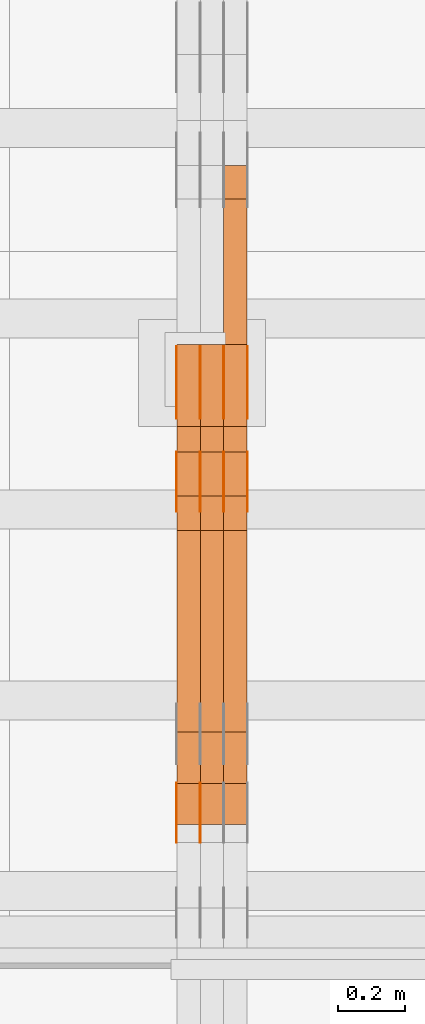
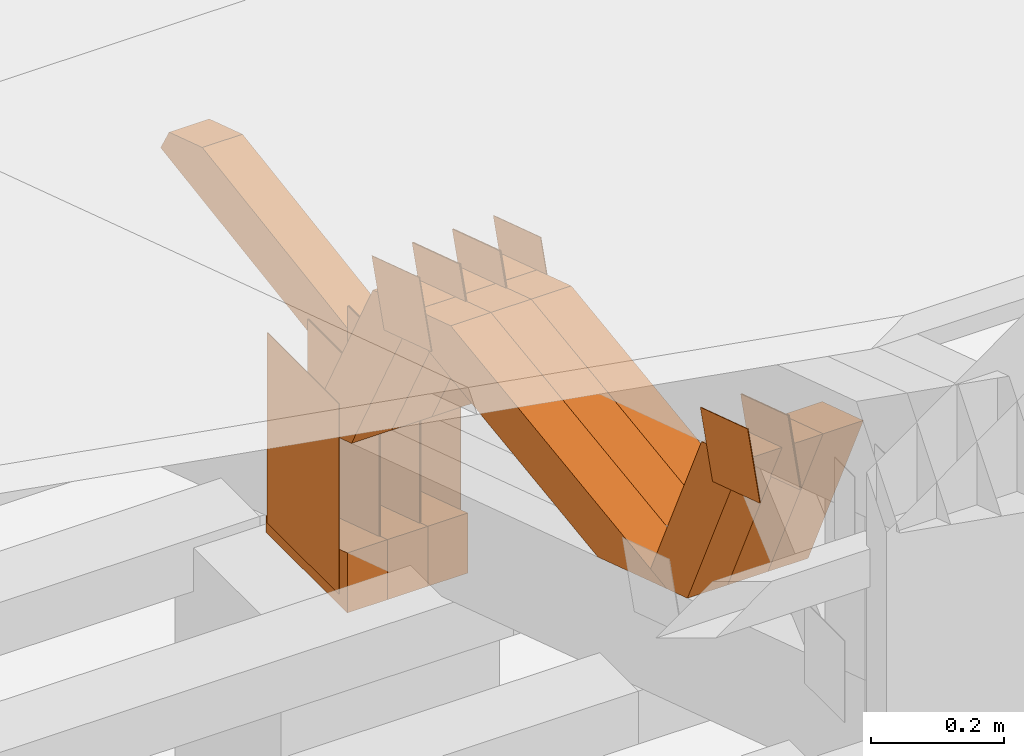
# One storey, part 148 of 385: 28 proxies.
"""IFC2X3 building model written with IfcOpenShell, lengths in millimetres."""

import ifcopenshell
import ifcopenshell.guid

model = None  # the IFC model being written
_history = None  # IfcOwnerHistory: only IFC2X3 demands one
_inside = {}  # id of a spatial element -> (the spatial element, [elements in it])
_under = {}  # id of a project, library or spatial element -> (it, [spatial elements below it])
_declared = {}  # id of a project -> (the project, [libraries it declares])
_typed = {}  # id of a type object -> (the type object, [elements of that type])
_made_of = {}  # id of a material, layer set ... -> (it, [elements and type objects made of it])


def new_model(schema):
    """Start an empty IFC model of exactly this schema.

    Asked for "IFC4X3", IfcOpenShell would pick the latest addendum, in which some entities
    have other attributes; the version numbers below select the first issue.
    IFC2X3 requires an IfcOwnerHistory on every rooted entity: one is made here for all.
    """
    global model, _history
    if schema == "IFC4X3":
        model = ifcopenshell.file(schema_version=(4, 3, 0, 0))
    else:
        model = ifcopenshell.file(schema=schema)
    _inside.clear()
    _under.clear()
    _declared.clear()
    _typed.clear()
    _made_of.clear()
    _history = None
    if model.schema == "IFC2X3":
        org = make("IfcOrganization", Name="unknown")
        user = make(
            "IfcPersonAndOrganization",
            ThePerson=make("IfcPerson", FamilyName="unknown"),
            TheOrganization=org,
        )
        app = make(
            "IfcApplication",
            ApplicationDeveloper=org,
            Version="unknown",
            ApplicationFullName="unknown",
            ApplicationIdentifier="unknown",
        )
        _history = make(
            "IfcOwnerHistory",
            OwningUser=user,
            OwningApplication=app,
            ChangeAction="ADDED",
            CreationDate=0,
        )
    return model


def make(cls, **values):
    """One entity of the class cls with the attributes given. An attribute that is None is left unset."""
    return model.create_entity(
        cls, **{name: value for name, value in values.items() if value is not None}
    )


def entity(cls, *values):
    """Any entity or typed value of the class cls, its attributes in the order of the schema. None: left unset."""
    e = model.create_entity(cls)
    for i, value in enumerate(values):
        if value is not None:
            e[i] = value
    return e


def rooted(cls, **values):
    """An entity with a GlobalId (a new one), such as an element, a storey or a relation."""
    return make(cls, GlobalId=ifcopenshell.guid.new(), OwnerHistory=_history, **values)


def si_unit(unit_type, name, prefix=None):
    """IfcSIUnit, for example si_unit("LENGTHUNIT", "METRE", prefix="MILLI")."""
    return make("IfcSIUnit", UnitType=unit_type, Prefix=prefix, Name=name)


def converted_unit(unit_type, name, factor, base, dimensions=None, offset=None):
    """IfcConversionBasedUnit, such as the inch: factor (a typed value) times the base unit."""
    return make(
        "IfcConversionBasedUnit"
        if offset is None
        else "IfcConversionBasedUnitWithOffset",
        ConversionOffset=offset,
        Dimensions=None
        if dimensions is None
        else entity("IfcDimensionalExponents", *dimensions),
        UnitType=unit_type,
        Name=name,
        ConversionFactor=make(
            "IfcMeasureWithUnit", ValueComponent=factor, UnitComponent=base
        ),
    )


def derived_unit(unit_type, elements):
    """IfcDerivedUnit: a product of units, each with its exponent."""
    return make(
        "IfcDerivedUnit",
        Elements=[
            make("IfcDerivedUnitElement", Unit=unit, Exponent=power)
            for unit, power in elements
        ],
        UnitType=unit_type,
    )


def assignment(units):
    """IfcUnitAssignment: the units of a project."""
    return None if units is None else make("IfcUnitAssignment", Units=units)


def point(xyz):
    """IfcCartesianPoint."""
    return None if xyz is None else make("IfcCartesianPoint", Coordinates=xyz)


def direction(xyz):
    """IfcDirection."""
    return None if xyz is None else make("IfcDirection", DirectionRatios=xyz)


def frame(location, z_axis=None, x_axis=None):
    """IfcAxis2Placement3D, a coordinate frame: its origin and axes. An axis left out is left unset."""
    return make(
        "IfcAxis2Placement3D",
        Location=point(location),
        Axis=direction(z_axis),
        RefDirection=direction(x_axis),
    )


def frame_2d(location, x_axis=None):
    """IfcAxis2Placement2D, a coordinate frame in the plane: its origin and x axis."""
    return make(
        "IfcAxis2Placement2D", Location=point(location), RefDirection=direction(x_axis)
    )


def origin():
    """The frame at (0, 0, 0) with its axes left unset."""
    return frame((0.0, 0.0, 0.0))


def origin_2d_with_axis():
    """The frame at (0, 0) in the plane with the x axis (1, 0) written out."""
    return frame_2d((0.0, 0.0), x_axis=(1.0, 0.0))


def place(relative_to, where):
    """IfcLocalPlacement: puts the frame where relative to a parent placement (None: the world)."""
    return make(
        "IfcLocalPlacement", PlacementRelTo=relative_to, RelativePlacement=where
    )


def context(
    kind, dimensions, precision=None, world=None, true_north=None, identifier=None
):
    """IfcGeometricRepresentationContext, for example the 3D "Model" context."""
    return make(
        "IfcGeometricRepresentationContext",
        ContextIdentifier=identifier,
        ContextType=kind,
        CoordinateSpaceDimension=dimensions,
        Precision=precision,
        WorldCoordinateSystem=world,
        TrueNorth=true_north,
    )


def subcontext(parent, identifier, kind, view, scale=None):
    """IfcGeometricRepresentationSubContext, for example "Body" below "Model"."""
    return make(
        "IfcGeometricRepresentationSubContext",
        ContextIdentifier=identifier,
        ContextType=kind,
        ParentContext=parent,
        TargetScale=scale,
        TargetView=view,
    )


def project(units=None, contexts=None):
    """IfcProject with its units and contexts."""
    return rooted(
        "IfcProject",
        Name="project",
        RepresentationContexts=contexts,
        UnitsInContext=assignment(units),
    )


def spatial(cls, under=None, at=None, **own):
    """A site, building, storey or space (cls), placed at a placement, below another one or the project."""
    s = rooted(cls, ObjectPlacement=at, **own)
    if under is not None:
        _under.setdefault(under.id(), (under, []))[1].append(s)
    return s


def polyline(points):
    """IfcPolyline through the points."""
    return make("IfcPolyline", Points=[point(p) for p in points])


def profile(cls, at=None, kind="AREA", **sizes):
    """A parametric profile (cls). Its sizes go by their IFC names, for example OverallWidth=200.0."""
    return make(cls, ProfileType=kind, Position=at, **sizes)


def rectangle(**sizes):
    """IfcRectangleProfileDef."""
    return profile("IfcRectangleProfileDef", **sizes)


def outline(outer, holes=None, kind="AREA"):
    """IfcArbitraryClosedProfileDef: a profile drawn as a closed curve; with holes, ...WithVoids."""
    if holes is None:
        return make("IfcArbitraryClosedProfileDef", ProfileType=kind, OuterCurve=outer)
    return make(
        "IfcArbitraryProfileDefWithVoids",
        ProfileType=kind,
        OuterCurve=outer,
        InnerCurves=holes,
    )


def extrude(swept, where, along, depth):
    """IfcExtrudedAreaSolid: the profile swept, set in the frame where, extruded along a direction by depth."""
    return make(
        "IfcExtrudedAreaSolid",
        SweptArea=swept,
        Position=where,
        ExtrudedDirection=direction(along),
        Depth=depth,
    )


def shape(context_of_items, identifier, shape_type, items):
    """IfcShapeRepresentation: the items that make up one representation, for example the "Body"."""
    return make(
        "IfcShapeRepresentation",
        ContextOfItems=context_of_items,
        RepresentationIdentifier=identifier,
        RepresentationType=shape_type,
        Items=items,
    )


def source(mapping_origin, context_of_items, identifier, shape_type, items):
    """IfcRepresentationMap: a shape defined once, which mapped items show again and again."""
    return make(
        "IfcRepresentationMap",
        MappingOrigin=mapping_origin,
        MappedRepresentation=shape(context_of_items, identifier, shape_type, items),
    )


def transform(
    local_origin,
    x_axis=None,
    y_axis=None,
    z_axis=None,
    scale=None,
    scale2=None,
    scale3=None,
    uniform=True,
):
    """IfcCartesianTransformationOperator3D, or its non-uniform kind. x_axis, y_axis, z_axis: its Axis1, 2, 3."""
    if uniform:
        return make(
            "IfcCartesianTransformationOperator3D",
            Axis1=direction(x_axis),
            Axis2=direction(y_axis),
            LocalOrigin=point(local_origin),
            Scale=scale,
            Axis3=direction(z_axis),
        )
    return make(
        "IfcCartesianTransformationOperator3DnonUniform",
        Axis1=direction(x_axis),
        Axis2=direction(y_axis),
        LocalOrigin=point(local_origin),
        Scale=scale,
        Axis3=direction(z_axis),
        Scale2=scale2,
        Scale3=scale3,
    )


def mapped(mapping_source, mapping_target):
    """IfcMappedItem: shows the shape of a source again, moved by a transform."""
    return make(
        "IfcMappedItem", MappingSource=mapping_source, MappingTarget=mapping_target
    )


def material(Name=None, Category=None):
    """IfcMaterial."""
    return make("IfcMaterial", Name=Name, Category=Category)


def made_of(thing, what):
    """Note that an element or type object is made of a material, layer set ...; save() writes the relation."""
    if what is not None:
        _made_of.setdefault(what.id(), (what, []))[1].append(thing)
    return thing


def type_object(cls, material=None, **own):
    """A type object (cls), such as IfcWallType, which elements share."""
    return made_of(rooted(cls, **own), material)


def type_shapes(of_type, sources):
    """Give a type object the sources (RepresentationMaps) that its elements show as mapped items."""
    of_type.RepresentationMaps = sources


def element(
    cls,
    number,
    at=None,
    inside=None,
    cuts=None,
    type_object=None,
    material=None,
    context=None,
    identifier="Body",
    shape_type=None,
    held_by="IfcProductDefinitionShape",
    body=None,
    shapes=None,
    **own,
):
    """One element of the class cls, such as IfcWall. Its Tag is "e" and its number.

    at: its placement. inside: the storey or other place that contains it. cuts: it is an
    opening in that element (IfcRelVoidsElement). A single representation is given by context,
    identifier, shape_type and body (its items); several are given by shapes. held_by: the class
    of the entity that holds the representations. save() writes the other relations.
    """
    e = rooted(cls, Tag="e%d" % number, ObjectPlacement=at, **own)
    if body is not None:
        shapes = [shape(context, identifier, shape_type, body)]
    if shapes is not None:
        e.Representation = make(held_by, Representations=shapes)
    if inside is not None:
        _inside.setdefault(inside.id(), (inside, []))[1].append(e)
    if cuts is not None:
        rooted(
            "IfcRelVoidsElement", RelatingBuildingElement=cuts, RelatedOpeningElement=e
        )
    if type_object is not None:
        _typed.setdefault(type_object.id(), (type_object, []))[1].append(e)
    return made_of(e, material)


def aggregate(whole, parts):
    """IfcRelAggregates: a whole, such as a stair, and the parts it consists of."""
    return rooted("IfcRelAggregates", RelatingObject=whole, RelatedObjects=parts)


def save(model, path):
    """Write the relations noted so far, then the file.

    IfcRelAggregates (storeys below a building ...), IfcRelContainedInSpatialStructure (elements
    in a storey), IfcRelDefinesByType, IfcRelAssociatesMaterial and IfcRelDeclares: one each for
    every whole, place, type object, material and project.
    """
    for whole, parts in _under.values():
        aggregate(whole, parts)
    for where, things in _inside.values():
        rooted(
            "IfcRelContainedInSpatialStructure",
            RelatedElements=things,
            RelatingStructure=where,
        )
    for kind, things in _typed.values():
        rooted("IfcRelDefinesByType", RelatedObjects=things, RelatingType=kind)
    for what, things in _made_of.values():
        rooted("IfcRelAssociatesMaterial", RelatedObjects=things, RelatingMaterial=what)
    for by, libraries in _declared.values():
        rooted("IfcRelDeclares", RelatingContext=by, RelatedDefinitions=libraries)
    model.write(path)


model = new_model("IFC2X3")

# Units and contexts
model_context = context("Model", 3, precision=0.01, world=origin(), true_north=direction((6.12303176911189e-17, 1.0)))
body_context = subcontext(model_context, "Body", "Model", "MODEL_VIEW")
ifc_project = project(units=[si_unit("LENGTHUNIT", "METRE", prefix="MILLI"), si_unit("AREAUNIT", "SQUARE_METRE"), si_unit("VOLUMEUNIT", "CUBIC_METRE"), converted_unit("PLANEANGLEUNIT", "DEGREE", entity("IfcRatioMeasure", 0.0174532925199433), si_unit("PLANEANGLEUNIT", "RADIAN"), dimensions=[0, 0, 0, 0, 0, 0, 0]), si_unit("MASSUNIT", "GRAM", prefix="KILO"), derived_unit("MASSDENSITYUNIT", [(si_unit("MASSUNIT", "GRAM", prefix="KILO"), 1), (si_unit("LENGTHUNIT", "METRE"), -3)]), si_unit("TIMEUNIT", "SECOND"), si_unit("FREQUENCYUNIT", "HERTZ"), si_unit("THERMODYNAMICTEMPERATUREUNIT", "DEGREE_CELSIUS"), derived_unit("THERMALTRANSMITTANCEUNIT", [(si_unit("MASSUNIT", "GRAM", prefix="KILO"), 1), (si_unit("THERMODYNAMICTEMPERATUREUNIT", "KELVIN"), -1), (si_unit("TIMEUNIT", "SECOND"), -3)]), derived_unit("VOLUMETRICFLOWRATEUNIT", [(si_unit("LENGTHUNIT", "METRE"), 3), (si_unit("TIMEUNIT", "SECOND"), -1)]), si_unit("ELECTRICCURRENTUNIT", "AMPERE"), si_unit("ELECTRICVOLTAGEUNIT", "VOLT"), si_unit("POWERUNIT", "WATT"), si_unit("FORCEUNIT", "NEWTON", prefix="KILO"), si_unit("ILLUMINANCEUNIT", "LUX"), si_unit("LUMINOUSFLUXUNIT", "LUMEN"), si_unit("LUMINOUSINTENSITYUNIT", "CANDELA"), derived_unit("USERDEFINED", [(si_unit("MASSUNIT", "GRAM", prefix="KILO"), -1), (si_unit("LENGTHUNIT", "METRE"), -2), (si_unit("TIMEUNIT", "SECOND"), 3), (si_unit("LUMINOUSFLUXUNIT", "LUMEN"), 1)]), derived_unit("LINEARVELOCITYUNIT", [(si_unit("LENGTHUNIT", "METRE"), 1), (si_unit("TIMEUNIT", "SECOND"), -1)]), si_unit("PRESSUREUNIT", "PASCAL"), derived_unit("USERDEFINED", [(si_unit("LENGTHUNIT", "METRE"), -2), (si_unit("MASSUNIT", "GRAM", prefix="KILO"), 1), (si_unit("TIMEUNIT", "SECOND"), -2)])], contexts=[model_context])

# Site, building, storey
site_placement = place(None, origin())
site = spatial("IfcSite", under=ifc_project, at=site_placement, CompositionType="ELEMENT")
building_placement = place(site_placement, origin())
building = spatial("IfcBuilding", under=site, at=building_placement, CompositionType="ELEMENT")
storey_placement = place(building_placement, origin())
storey = spatial("IfcBuildingStorey", under=building, at=storey_placement, Name="Default", CompositionType="ELEMENT", Elevation=0.0)

# Proxies
ifc_material_1 = material(Name="IfcSurfaceStyle #237074")
building_element_proxy_type_1 = type_object("IfcBuildingElementProxyType", PredefinedType="NOTDEFINED", material=ifc_material_1)
shared_shape_1 = source(origin(), body_context, "Body", "SweptSolid", [
    extrude(rectangle(XDim=350.0, YDim=215.999999999984, at=origin_2d_with_axis()), frame((175.0, 108.0, 0.0), z_axis=(0.0, 0.0, 1.0), x_axis=(-1.0, 0.0, 0.0)), (0.0, 0.0, 1.0), 1.29999999999999),
])
type_shapes(building_element_proxy_type_1, [shared_shape_1])
proxy_1_placement = place(building_placement, frame((18386.3, 17459.2939453125, 3165.36425781251), z_axis=(-1.0, 0.0, 0.0), x_axis=(0.0, 0.0, -1.0)))
element("IfcBuildingElementProxy", 1, at=proxy_1_placement, inside=storey, type_object=building_element_proxy_type_1, material=ifc_material_1, context=body_context, shape_type="MappedRepresentation", body=[
    mapped(shared_shape_1, transform((0.0, 0.0, 0.0), scale=1.0)),
])
ifc_material_2 = material(Name="IfcSurfaceStyle #237017")
building_element_proxy_type_2 = type_object("IfcBuildingElementProxyType", PredefinedType="NOTDEFINED", material=ifc_material_2)
shared_shape_2 = source(origin(), body_context, "Body", "SweptSolid", [
    extrude(rectangle(XDim=350.0, YDim=215.999999999984, at=origin_2d_with_axis()), frame((175.0, 108.0, 0.0), z_axis=(0.0, 0.0, 1.0), x_axis=(-1.0, 0.0, 0.0)), (0.0, 0.0, 1.0), 1.29999999999999),
])
type_shapes(building_element_proxy_type_2, [shared_shape_2])
proxy_2_placement = place(building_placement, frame((18315.0, 17459.2939453125, 3165.36425781251), z_axis=(-1.0, 0.0, 0.0), x_axis=(0.0, 0.0, -1.0)))
element("IfcBuildingElementProxy", 2, at=proxy_2_placement, inside=storey, type_object=building_element_proxy_type_2, material=ifc_material_2, context=body_context, shape_type="MappedRepresentation", body=[
    mapped(shared_shape_2, transform((0.0, 0.0, 0.0), scale=1.0)),
])
ifc_material_3 = material(Name="IfcSurfaceStyle #236960")
building_element_proxy_type_3 = type_object("IfcBuildingElementProxyType", PredefinedType="NOTDEFINED", material=ifc_material_3)
shared_shape_3 = source(origin(), body_context, "Body", "SweptSolid", [
    extrude(rectangle(XDim=350.0, YDim=215.999999999984, at=origin_2d_with_axis()), frame((175.0, 108.0, 0.0), z_axis=(0.0, 0.0, 1.0), x_axis=(-1.0, 0.0, 0.0)), (0.0, 0.0, 1.0), 1.29999999999999),
])
type_shapes(building_element_proxy_type_3, [shared_shape_3])
proxy_3_placement = place(building_placement, frame((18316.3, 17459.2939453125, 3165.36425781251), z_axis=(-1.0, 0.0, 0.0), x_axis=(0.0, 0.0, -1.0)))
element("IfcBuildingElementProxy", 3, at=proxy_3_placement, inside=storey, type_object=building_element_proxy_type_3, material=ifc_material_3, context=body_context, shape_type="MappedRepresentation", body=[
    mapped(shared_shape_3, transform((0.0, 0.0, 0.0), scale=1.0)),
])
ifc_material_4 = material(Name="IfcSurfaceStyle #236903")
building_element_proxy_type_4 = type_object("IfcBuildingElementProxyType", PredefinedType="NOTDEFINED", material=ifc_material_4)
shared_shape_4 = source(origin(), body_context, "Body", "SweptSolid", [
    extrude(rectangle(XDim=350.0, YDim=215.999999999984, at=origin_2d_with_axis()), frame((175.0, 108.0, 0.0), z_axis=(0.0, 0.0, 1.0), x_axis=(-1.0, 0.0, 0.0)), (0.0, 0.0, 1.0), 1.29999999999998),
])
type_shapes(building_element_proxy_type_4, [shared_shape_4])
proxy_4_placement = place(building_placement, frame((18245.0, 17459.2939453125, 3165.36425781251), z_axis=(-1.0, 0.0, 0.0), x_axis=(0.0, 0.0, -1.0)))
element("IfcBuildingElementProxy", 4, at=proxy_4_placement, inside=storey, type_object=building_element_proxy_type_4, material=ifc_material_4, context=body_context, shape_type="MappedRepresentation", body=[
    mapped(shared_shape_4, transform((0.0, 0.0, 0.0), scale=1.0)),
])
ifc_material_5 = material(Name="IfcSurfaceStyle #236846")
building_element_proxy_type_5 = type_object("IfcBuildingElementProxyType", PredefinedType="NOTDEFINED", material=ifc_material_5)
shared_shape_5 = source(origin(), body_context, "Body", "SweptSolid", [
    extrude(rectangle(XDim=350.0, YDim=215.999999999984, at=origin_2d_with_axis()), frame((175.0, 108.0, 0.0), z_axis=(0.0, 0.0, 1.0), x_axis=(-1.0, 0.0, 0.0)), (0.0, 0.0, 1.0), 1.29999999999998),
])
type_shapes(building_element_proxy_type_5, [shared_shape_5])
proxy_5_placement = place(building_placement, frame((18246.3, 17459.2939453125, 3165.36425781251), z_axis=(-1.0, 0.0, 0.0), x_axis=(0.0, 0.0, -1.0)))
element("IfcBuildingElementProxy", 5, at=proxy_5_placement, inside=storey, type_object=building_element_proxy_type_5, material=ifc_material_5, context=body_context, shape_type="MappedRepresentation", body=[
    mapped(shared_shape_5, transform((0.0, 0.0, 0.0), scale=1.0)),
])
ifc_material_6 = material(Name="IfcSurfaceStyle #236789")
building_element_proxy_type_6 = type_object("IfcBuildingElementProxyType", PredefinedType="NOTDEFINED", material=ifc_material_6)
shared_shape_6 = source(origin(), body_context, "Body", "SweptSolid", [
    extrude(rectangle(XDim=350.0, YDim=215.999999999984, at=origin_2d_with_axis()), frame((175.0, 108.0, 0.0), z_axis=(0.0, 0.0, 1.0), x_axis=(-1.0, 0.0, 0.0)), (0.0, 0.0, 1.0), 1.29999999999998),
])
type_shapes(building_element_proxy_type_6, [shared_shape_6])
proxy_6_placement = place(building_placement, frame((18175.0, 17459.2939453125, 3165.36425781251), z_axis=(-1.0, 0.0, 0.0), x_axis=(0.0, 0.0, -1.0)))
element("IfcBuildingElementProxy", 6, at=proxy_6_placement, inside=storey, type_object=building_element_proxy_type_6, material=ifc_material_6, context=body_context, shape_type="MappedRepresentation", body=[
    mapped(shared_shape_6, transform((0.0, 0.0, 0.0), scale=1.0)),
])
ifc_material_7 = material(Name="IfcSurfaceStyle #234851")
building_element_proxy_type_7 = type_object("IfcBuildingElementProxyType", PredefinedType="NOTDEFINED", material=ifc_material_7)
shared_shape_7 = source(origin(), body_context, "Body", "SweptSolid", [
    extrude(outline(polyline([(-75.0003249421702, -60.0000773549573), (75.0003398116874, -60.0000773549573), (75.0003249421711, 60.0000773549573), (-75.0003398116883, 60.0000773549573), (-75.0003249421702, -60.0000773549573)])), frame((75.0003398116874, 60.0000773549573, 0.0), z_axis=(0.0, 0.0, 1.0), x_axis=(-1.0, 0.0, 0.0)), (0.0, 0.0, 1.0), 1.29999999999999),
])
type_shapes(building_element_proxy_type_7, [shared_shape_7])
proxy_7_placement = place(building_placement, frame((18245.0, 16117.0849050545, 3705.49074668796), z_axis=(-1.0, 0.0, 0.0), x_axis=(0.0, -0.951056516295154, 0.309016994374948)))
element("IfcBuildingElementProxy", 7, at=proxy_7_placement, inside=storey, type_object=building_element_proxy_type_7, material=ifc_material_7, context=body_context, shape_type="MappedRepresentation", body=[
    mapped(shared_shape_7, transform((0.0, 0.0, 0.0), scale=1.0)),
])
ifc_material_8 = material(Name="IfcSurfaceStyle #234794")
building_element_proxy_type_8 = type_object("IfcBuildingElementProxyType", PredefinedType="NOTDEFINED", material=ifc_material_8)
shared_shape_8 = source(origin(), body_context, "Body", "SweptSolid", [
    extrude(outline(polyline([(-75.0003249421702, -60.0000773549573), (75.0003398116874, -60.0000773549573), (75.0003249421711, 60.0000773549573), (-75.0003398116883, 60.0000773549573), (-75.0003249421702, -60.0000773549573)])), frame((75.0003398116874, 60.0000773549573, 0.0), z_axis=(0.0, 0.0, 1.0), x_axis=(-1.0, 0.0, 0.0)), (0.0, 0.0, 1.0), 1.29999999999999),
])
type_shapes(building_element_proxy_type_8, [shared_shape_8])
proxy_8_placement = place(building_placement, frame((18246.3, 16117.0849050545, 3705.49074668796), z_axis=(-1.0, 0.0, 0.0), x_axis=(0.0, -0.951056516295154, 0.309016994374948)))
element("IfcBuildingElementProxy", 8, at=proxy_8_placement, inside=storey, type_object=building_element_proxy_type_8, material=ifc_material_8, context=body_context, shape_type="MappedRepresentation", body=[
    mapped(shared_shape_8, transform((0.0, 0.0, 0.0), scale=1.0)),
])
ifc_material_9 = material(Name="IfcSurfaceStyle #234737")
building_element_proxy_type_9 = type_object("IfcBuildingElementProxyType", PredefinedType="NOTDEFINED", material=ifc_material_9)
shared_shape_9 = source(origin(), body_context, "Body", "SweptSolid", [
    extrude(outline(polyline([(-75.0003249421702, -60.0000773549573), (75.0003398116874, -60.0000773549573), (75.0003249421711, 60.0000773549573), (-75.0003398116883, 60.0000773549573), (-75.0003249421702, -60.0000773549573)])), frame((75.0003398116874, 60.0000773549573, 0.0), z_axis=(0.0, 0.0, 1.0), x_axis=(-1.0, 0.0, 0.0)), (0.0, 0.0, 1.0), 1.29999999999999),
])
type_shapes(building_element_proxy_type_9, [shared_shape_9])
proxy_9_placement = place(building_placement, frame((18175.0, 16117.0849050545, 3705.49074668796), z_axis=(-1.0, 0.0, 0.0), x_axis=(0.0, -0.951056516295154, 0.309016994374948)))
element("IfcBuildingElementProxy", 9, at=proxy_9_placement, inside=storey, type_object=building_element_proxy_type_9, material=ifc_material_9, context=body_context, shape_type="MappedRepresentation", body=[
    mapped(shared_shape_9, transform((0.0, 0.0, 0.0), scale=1.0)),
])
ifc_material_10 = material(Name="IfcSurfaceStyle #233654")
building_element_proxy_type_10 = type_object("IfcBuildingElementProxyType", PredefinedType="NOTDEFINED", material=ifc_material_10)
shared_shape_10 = source(origin(), body_context, "Body", "SweptSolid", [
    extrude(outline(polyline([(-74.9998605591058, -59.9999264677524), (74.999875428623, -59.9999264677524), (74.9998605591068, 59.9999264677524), (-74.9998754286239, 59.9999264677524), (-74.9998605591058, -59.9999264677524)])), frame((75.0002460484325, 60.0000016373508, 0.0), z_axis=(0.0, 0.0, 1.0), x_axis=(-1.0, 0.0, 0.0)), (0.0, 0.0, 1.0), 1.3),
])
type_shapes(building_element_proxy_type_10, [shared_shape_10])
proxy_10_placement = place(building_placement, frame((18386.3, 17107.0599369346, 3383.82825001787), z_axis=(-1.0, 0.0, 0.0), x_axis=(0.0, -0.951056516295154, 0.309016994374948)))
element("IfcBuildingElementProxy", 10, at=proxy_10_placement, inside=storey, type_object=building_element_proxy_type_10, material=ifc_material_10, context=body_context, shape_type="MappedRepresentation", body=[
    mapped(shared_shape_10, transform((0.0, 0.0, 0.0), scale=1.0)),
])
ifc_material_11 = material(Name="IfcSurfaceStyle #233597")
building_element_proxy_type_11 = type_object("IfcBuildingElementProxyType", PredefinedType="NOTDEFINED", material=ifc_material_11)
shared_shape_11 = source(origin(), body_context, "Body", "SweptSolid", [
    extrude(outline(polyline([(-74.9998605591058, -59.9999264677524), (74.999875428623, -59.9999264677524), (74.9998605591068, 59.9999264677524), (-74.9998754286239, 59.9999264677524), (-74.9998605591058, -59.9999264677524)])), frame((75.0002460484325, 60.0000016373508, 0.0), z_axis=(0.0, 0.0, 1.0), x_axis=(-1.0, 0.0, 0.0)), (0.0, 0.0, 1.0), 1.3),
])
type_shapes(building_element_proxy_type_11, [shared_shape_11])
proxy_11_placement = place(building_placement, frame((18315.0, 17107.0599369346, 3383.82825001787), z_axis=(-1.0, 0.0, 0.0), x_axis=(0.0, -0.951056516295154, 0.309016994374948)))
element("IfcBuildingElementProxy", 11, at=proxy_11_placement, inside=storey, type_object=building_element_proxy_type_11, material=ifc_material_11, context=body_context, shape_type="MappedRepresentation", body=[
    mapped(shared_shape_11, transform((0.0, 0.0, 0.0), scale=1.0)),
])
ifc_material_12 = material(Name="IfcSurfaceStyle #233540")
building_element_proxy_type_12 = type_object("IfcBuildingElementProxyType", PredefinedType="NOTDEFINED", material=ifc_material_12)
shared_shape_12 = source(origin(), body_context, "Body", "SweptSolid", [
    extrude(outline(polyline([(-74.9998605591058, -59.9999264677524), (74.999875428623, -59.9999264677524), (74.9998605591068, 59.9999264677524), (-74.9998754286239, 59.9999264677524), (-74.9998605591058, -59.9999264677524)])), frame((75.0002460484325, 60.0000016373508, 0.0), z_axis=(0.0, 0.0, 1.0), x_axis=(-1.0, 0.0, 0.0)), (0.0, 0.0, 1.0), 1.3),
])
type_shapes(building_element_proxy_type_12, [shared_shape_12])
proxy_12_placement = place(building_placement, frame((18316.3, 17107.0599369346, 3383.82825001787), z_axis=(-1.0, 0.0, 0.0), x_axis=(0.0, -0.951056516295154, 0.309016994374948)))
element("IfcBuildingElementProxy", 12, at=proxy_12_placement, inside=storey, type_object=building_element_proxy_type_12, material=ifc_material_12, context=body_context, shape_type="MappedRepresentation", body=[
    mapped(shared_shape_12, transform((0.0, 0.0, 0.0), scale=1.0)),
])
ifc_material_13 = material(Name="IfcSurfaceStyle #233483")
building_element_proxy_type_13 = type_object("IfcBuildingElementProxyType", PredefinedType="NOTDEFINED", material=ifc_material_13)
shared_shape_13 = source(origin(), body_context, "Body", "SweptSolid", [
    extrude(outline(polyline([(-74.9998605591058, -59.9999264677524), (74.999875428623, -59.9999264677524), (74.9998605591068, 59.9999264677524), (-74.9998754286239, 59.9999264677524), (-74.9998605591058, -59.9999264677524)])), frame((75.0002460484325, 60.0000016373508, 0.0), z_axis=(0.0, 0.0, 1.0), x_axis=(-1.0, 0.0, 0.0)), (0.0, 0.0, 1.0), 1.29999999999999),
])
type_shapes(building_element_proxy_type_13, [shared_shape_13])
proxy_13_placement = place(building_placement, frame((18245.0, 17107.0599369346, 3383.82825001787), z_axis=(-1.0, 0.0, 0.0), x_axis=(0.0, -0.951056516295154, 0.309016994374948)))
element("IfcBuildingElementProxy", 13, at=proxy_13_placement, inside=storey, type_object=building_element_proxy_type_13, material=ifc_material_13, context=body_context, shape_type="MappedRepresentation", body=[
    mapped(shared_shape_13, transform((0.0, 0.0, 0.0), scale=1.0)),
])
ifc_material_14 = material(Name="IfcSurfaceStyle #233426")
building_element_proxy_type_14 = type_object("IfcBuildingElementProxyType", PredefinedType="NOTDEFINED", material=ifc_material_14)
shared_shape_14 = source(origin(), body_context, "Body", "SweptSolid", [
    extrude(outline(polyline([(-74.9998605591058, -59.9999264677524), (74.999875428623, -59.9999264677524), (74.9998605591068, 59.9999264677524), (-74.9998754286239, 59.9999264677524), (-74.9998605591058, -59.9999264677524)])), frame((75.0002460484325, 60.0000016373508, 0.0), z_axis=(0.0, 0.0, 1.0), x_axis=(-1.0, 0.0, 0.0)), (0.0, 0.0, 1.0), 1.29999999999999),
])
type_shapes(building_element_proxy_type_14, [shared_shape_14])
proxy_14_placement = place(building_placement, frame((18246.3, 17107.0599369346, 3383.82825001787), z_axis=(-1.0, 0.0, 0.0), x_axis=(0.0, -0.951056516295154, 0.309016994374948)))
element("IfcBuildingElementProxy", 14, at=proxy_14_placement, inside=storey, type_object=building_element_proxy_type_14, material=ifc_material_14, context=body_context, shape_type="MappedRepresentation", body=[
    mapped(shared_shape_14, transform((0.0, 0.0, 0.0), scale=1.0)),
])
ifc_material_15 = material(Name="IfcSurfaceStyle #233369")
building_element_proxy_type_15 = type_object("IfcBuildingElementProxyType", PredefinedType="NOTDEFINED", material=ifc_material_15)
shared_shape_15 = source(origin(), body_context, "Body", "SweptSolid", [
    extrude(outline(polyline([(-74.9998605591058, -59.9999264677524), (74.999875428623, -59.9999264677524), (74.9998605591068, 59.9999264677524), (-74.9998754286239, 59.9999264677524), (-74.9998605591058, -59.9999264677524)])), frame((75.0002460484325, 60.0000016373508, 0.0), z_axis=(0.0, 0.0, 1.0), x_axis=(-1.0, 0.0, 0.0)), (0.0, 0.0, 1.0), 1.29999999999999),
])
type_shapes(building_element_proxy_type_15, [shared_shape_15])
proxy_15_placement = place(building_placement, frame((18175.0, 17107.0599369346, 3383.82825001787), z_axis=(-1.0, 0.0, 0.0), x_axis=(0.0, -0.951056516295154, 0.309016994374948)))
element("IfcBuildingElementProxy", 15, at=proxy_15_placement, inside=storey, type_object=building_element_proxy_type_15, material=ifc_material_15, context=body_context, shape_type="MappedRepresentation", body=[
    mapped(shared_shape_15, transform((0.0, 0.0, 0.0), scale=1.0)),
])
ifc_material_16 = material(Name="IfcSurfaceStyle #225365")
building_element_proxy_type_16 = type_object("IfcBuildingElementProxyType", Name="T1-E1 225363", PredefinedType="NOTDEFINED", material=ifc_material_16)
shared_shape_16 = source(origin(), body_context, "Body", "SweptSolid", [
    extrude(outline(polyline([(4.4675903320374, -122.500000000001), (35.3350219726624, -122.500000000001), (35.3350219726501, 122.500000000001), (-75.1376342773499, 122.500000000001), (4.4675903320374, -122.500000000001)])), frame((35.3350219726624, 122.50000005215, 0.0), z_axis=(0.0, 0.0, 1.0), x_axis=(-1.0, 0.0, 0.0)), (0.0, 0.0, 1.0), 70.0),
])
type_shapes(building_element_proxy_type_16, [shared_shape_16])
proxy_16_placement = place(building_placement, frame((18385.0, 17220.0, 2794.30932617186), z_axis=(-1.0, 0.0, 0.0), x_axis=(0.0, 0.0, 1.0)))
element("IfcBuildingElementProxy", 16, at=proxy_16_placement, inside=storey, type_object=building_element_proxy_type_16, material=ifc_material_16, Name="T1-E1", context=body_context, shape_type="MappedRepresentation", body=[
    mapped(shared_shape_16, transform((0.0, 0.0, 0.0), scale=1.0)),
])
ifc_material_17 = material(Name="IfcSurfaceStyle #225308")
building_element_proxy_type_17 = type_object("IfcBuildingElementProxyType", Name="T1-E1 225306", PredefinedType="NOTDEFINED", material=ifc_material_17)
shared_shape_17 = source(origin(), body_context, "Body", "SweptSolid", [
    extrude(outline(polyline([(4.4675903320374, -122.500000000001), (35.3350219726624, -122.500000000001), (35.3350219726501, 122.500000000001), (-75.1376342773499, 122.500000000001), (4.4675903320374, -122.500000000001)])), frame((35.3350219726624, 122.50000005215, 0.0), z_axis=(0.0, 0.0, 1.0), x_axis=(-1.0, 0.0, 0.0)), (0.0, 0.0, 1.0), 70.0),
])
type_shapes(building_element_proxy_type_17, [shared_shape_17])
proxy_17_placement = place(building_placement, frame((18315.0, 17220.0, 2794.30932617186), z_axis=(-1.0, 0.0, 0.0), x_axis=(0.0, 0.0, 1.0)))
element("IfcBuildingElementProxy", 17, at=proxy_17_placement, inside=storey, type_object=building_element_proxy_type_17, material=ifc_material_17, Name="T1-E1", context=body_context, shape_type="MappedRepresentation", body=[
    mapped(shared_shape_17, transform((0.0, 0.0, 0.0), scale=1.0)),
])
ifc_material_18 = material(Name="IfcSurfaceStyle #225251")
building_element_proxy_type_18 = type_object("IfcBuildingElementProxyType", Name="T1-E1 225249", PredefinedType="NOTDEFINED", material=ifc_material_18)
shared_shape_18 = source(origin(), body_context, "Body", "SweptSolid", [
    extrude(outline(polyline([(4.4675903320374, -122.500000000001), (35.3350219726624, -122.500000000001), (35.3350219726501, 122.500000000001), (-75.1376342773499, 122.500000000001), (4.4675903320374, -122.500000000001)])), frame((35.3350219726624, 122.50000005215, 0.0), z_axis=(0.0, 0.0, 1.0), x_axis=(-1.0, 0.0, 0.0)), (0.0, 0.0, 1.0), 70.0),
])
type_shapes(building_element_proxy_type_18, [shared_shape_18])
proxy_18_placement = place(building_placement, frame((18245.0, 17220.0, 2794.30932617186), z_axis=(-1.0, 0.0, 0.0), x_axis=(0.0, 0.0, 1.0)))
element("IfcBuildingElementProxy", 18, at=proxy_18_placement, inside=storey, type_object=building_element_proxy_type_18, material=ifc_material_18, Name="T1-E1", context=body_context, shape_type="MappedRepresentation", body=[
    mapped(shared_shape_18, transform((0.0, 0.0, 0.0), scale=1.0)),
])
ifc_material_19 = material(Name="IfcSurfaceStyle #224402")
building_element_proxy_type_19 = type_object("IfcBuildingElementProxyType", Name="T1-W44 224400", PredefinedType="NOTDEFINED", material=ifc_material_19)
shared_shape_19 = source(origin(), body_context, "Body", "SweptSolid", [
    extrude(outline(polyline([(-184.551057772692, -47.4997984945814), (177.527112951531, -47.4997984945814), (162.630077773546, -0.000452497529500495), (118.068221667048, 47.5000247433462), (-273.674354619433, 47.5000247433462), (-184.551057772692, -47.4997984945814)])), frame((177.527112951531, 47.5002721629815, 0.0), z_axis=(0.0, 0.0, 1.0), x_axis=(-1.0, 0.0, 0.0)), (0.0, 0.0, 1.0), 70.0),
])
type_shapes(building_element_proxy_type_19, [shared_shape_19])
proxy_19_placement = place(building_placement, frame((18385.0, 16220.4899216004, 3388.98238154171), z_axis=(-1.0, 0.0, 0.0), x_axis=(0.0, -0.425335045192995, 0.905035965766374)))
element("IfcBuildingElementProxy", 19, at=proxy_19_placement, inside=storey, type_object=building_element_proxy_type_19, material=ifc_material_19, Name="T1-W44", context=body_context, shape_type="MappedRepresentation", body=[
    mapped(shared_shape_19, transform((0.0, 0.0, 0.0), scale=1.0)),
])
ifc_material_20 = material(Name="IfcSurfaceStyle #224336")
building_element_proxy_type_20 = type_object("IfcBuildingElementProxyType", Name="T1-W44 224334", PredefinedType="NOTDEFINED", material=ifc_material_20)
shared_shape_20 = source(origin(), body_context, "Body", "SweptSolid", [
    extrude(outline(polyline([(-184.551057772692, -47.4997984945814), (177.527112951531, -47.4997984945814), (162.630077773546, -0.000452497529500495), (118.068221667048, 47.5000247433462), (-273.674354619433, 47.5000247433462), (-184.551057772692, -47.4997984945814)])), frame((177.527112951531, 47.5002721629815, 0.0), z_axis=(0.0, 0.0, 1.0), x_axis=(-1.0, 0.0, 0.0)), (0.0, 0.0, 1.0), 70.0),
])
type_shapes(building_element_proxy_type_20, [shared_shape_20])
proxy_20_placement = place(building_placement, frame((18315.0, 16220.4899216004, 3388.98238154171), z_axis=(-1.0, 0.0, 0.0), x_axis=(0.0, -0.425335045192995, 0.905035965766374)))
element("IfcBuildingElementProxy", 20, at=proxy_20_placement, inside=storey, type_object=building_element_proxy_type_20, material=ifc_material_20, Name="T1-W44", context=body_context, shape_type="MappedRepresentation", body=[
    mapped(shared_shape_20, transform((0.0, 0.0, 0.0), scale=1.0)),
])
ifc_material_21 = material(Name="IfcSurfaceStyle #224270")
building_element_proxy_type_21 = type_object("IfcBuildingElementProxyType", Name="T1-W44 224268", PredefinedType="NOTDEFINED", material=ifc_material_21)
shared_shape_21 = source(origin(), body_context, "Body", "SweptSolid", [
    extrude(outline(polyline([(-184.551057772692, -47.4997984945814), (177.527112951531, -47.4997984945814), (162.630077773546, -0.000452497529500495), (118.068221667048, 47.5000247433462), (-273.674354619433, 47.5000247433462), (-184.551057772692, -47.4997984945814)])), frame((177.527112951531, 47.5002721629815, 0.0), z_axis=(0.0, 0.0, 1.0), x_axis=(-1.0, 0.0, 0.0)), (0.0, 0.0, 1.0), 70.0),
])
type_shapes(building_element_proxy_type_21, [shared_shape_21])
proxy_21_placement = place(building_placement, frame((18245.0, 16220.4899216004, 3388.98238154171), z_axis=(-1.0, 0.0, 0.0), x_axis=(0.0, -0.425335045192995, 0.905035965766374)))
element("IfcBuildingElementProxy", 21, at=proxy_21_placement, inside=storey, type_object=building_element_proxy_type_21, material=ifc_material_21, Name="T1-W44", context=body_context, shape_type="MappedRepresentation", body=[
    mapped(shared_shape_21, transform((0.0, 0.0, 0.0), scale=1.0)),
])
ifc_material_22 = material(Name="IfcSurfaceStyle #224006")
building_element_proxy_type_22 = type_object("IfcBuildingElementProxyType", Name="T1-W8 224004", PredefinedType="NOTDEFINED", material=ifc_material_22)
shared_shape_22 = source(origin(), body_context, "Body", "SweptSolid", [
    extrude(outline(polyline([(-476.725263324644, -47.5001051695965), (180.672765845439, -47.5001051695965), (279.11020091716, -1.03605560390907e-06), (296.793624402619, 47.5001056876243), (-279.851327840575, 47.5001056876243), (-476.725263324644, -47.5001051695965)])), frame((296.793624402619, 47.5001056876243, 0.0), z_axis=(0.0, 0.0, 1.0), x_axis=(-1.0, 0.0, 0.0)), (0.0, 0.0, 1.0), 70.0),
])
type_shapes(building_element_proxy_type_22, [shared_shape_22])
proxy_22_placement = place(building_placement, frame((18385.0, 17036.40625, 3432.97192382813), z_axis=(-1.0, 0.0, 0.0), x_axis=(0.0, -0.990844046556832, -0.135011389900564)))
element("IfcBuildingElementProxy", 22, at=proxy_22_placement, inside=storey, type_object=building_element_proxy_type_22, material=ifc_material_22, Name="T1-W8", context=body_context, shape_type="MappedRepresentation", body=[
    mapped(shared_shape_22, transform((0.0, 0.0, 0.0), scale=1.0)),
])
ifc_material_23 = material(Name="IfcSurfaceStyle #223940")
building_element_proxy_type_23 = type_object("IfcBuildingElementProxyType", Name="T1-W8 223938", PredefinedType="NOTDEFINED", material=ifc_material_23)
shared_shape_23 = source(origin(), body_context, "Body", "SweptSolid", [
    extrude(outline(polyline([(-476.725263324644, -47.5001051695965), (180.672765845439, -47.5001051695965), (279.11020091716, -1.03605560390907e-06), (296.793624402619, 47.5001056876243), (-279.851327840575, 47.5001056876243), (-476.725263324644, -47.5001051695965)])), frame((296.793624402619, 47.5001056876243, 0.0), z_axis=(0.0, 0.0, 1.0), x_axis=(-1.0, 0.0, 0.0)), (0.0, 0.0, 1.0), 70.0),
])
type_shapes(building_element_proxy_type_23, [shared_shape_23])
proxy_23_placement = place(building_placement, frame((18315.0, 17036.40625, 3432.97192382813), z_axis=(-1.0, 0.0, 0.0), x_axis=(0.0, -0.990844046556832, -0.135011389900564)))
element("IfcBuildingElementProxy", 23, at=proxy_23_placement, inside=storey, type_object=building_element_proxy_type_23, material=ifc_material_23, Name="T1-W8", context=body_context, shape_type="MappedRepresentation", body=[
    mapped(shared_shape_23, transform((0.0, 0.0, 0.0), scale=1.0)),
])
ifc_material_24 = material(Name="IfcSurfaceStyle #223874")
building_element_proxy_type_24 = type_object("IfcBuildingElementProxyType", Name="T1-W8 223872", PredefinedType="NOTDEFINED", material=ifc_material_24)
shared_shape_24 = source(origin(), body_context, "Body", "SweptSolid", [
    extrude(outline(polyline([(-476.725263324644, -47.5001051695965), (180.672765845439, -47.5001051695965), (279.11020091716, -1.03605560390907e-06), (296.793624402619, 47.5001056876243), (-279.851327840575, 47.5001056876243), (-476.725263324644, -47.5001051695965)])), frame((296.793624402619, 47.5001056876243, 0.0), z_axis=(0.0, 0.0, 1.0), x_axis=(-1.0, 0.0, 0.0)), (0.0, 0.0, 1.0), 70.0),
])
type_shapes(building_element_proxy_type_24, [shared_shape_24])
proxy_24_placement = place(building_placement, frame((18245.0, 17036.40625, 3432.97192382813), z_axis=(-1.0, 0.0, 0.0), x_axis=(0.0, -0.990844046556832, -0.135011389900564)))
element("IfcBuildingElementProxy", 24, at=proxy_24_placement, inside=storey, type_object=building_element_proxy_type_24, material=ifc_material_24, Name="T1-W8", context=body_context, shape_type="MappedRepresentation", body=[
    mapped(shared_shape_24, transform((0.0, 0.0, 0.0), scale=1.0)),
])
ifc_material_25 = material(Name="IfcSurfaceStyle #223610")
building_element_proxy_type_25 = type_object("IfcBuildingElementProxyType", Name="T1-W39 223608", PredefinedType="NOTDEFINED", material=ifc_material_25)
shared_shape_25 = source(origin(), body_context, "Body", "SweptSolid", [
    extrude(outline(polyline([(-191.519946663886, -47.499928106579), (188.32936223763, -47.499928106579), (171.597440144109, 0.000249483340993841), (122.102882529753, 47.4998033649085), (-290.509738247605, 47.4998033649085), (-191.519946663886, -47.499928106579)])), frame((188.329593252001, 47.499957247623, 0.0), z_axis=(0.0, 0.0, 1.0), x_axis=(-1.0, 0.0, 0.0)), (0.0, 0.0, 1.0), 70.0),
])
type_shapes(building_element_proxy_type_25, [shared_shape_25])
proxy_25_placement = place(building_placement, frame((18385.0, 17238.5876916597, 3055.56121424762), z_axis=(-1.0, 0.0, 0.0), x_axis=(0.0, -0.472216932390777, 0.881482370080902)))
element("IfcBuildingElementProxy", 25, at=proxy_25_placement, inside=storey, type_object=building_element_proxy_type_25, material=ifc_material_25, Name="T1-W39", context=body_context, shape_type="MappedRepresentation", body=[
    mapped(shared_shape_25, transform((0.0, 0.0, 0.0), scale=1.0)),
])
ifc_material_26 = material(Name="IfcSurfaceStyle #223544")
building_element_proxy_type_26 = type_object("IfcBuildingElementProxyType", Name="T1-W39 223542", PredefinedType="NOTDEFINED", material=ifc_material_26)
shared_shape_26 = source(origin(), body_context, "Body", "SweptSolid", [
    extrude(outline(polyline([(-191.519946663886, -47.499928106579), (188.32936223763, -47.499928106579), (171.597440144109, 0.000249483340993841), (122.102882529753, 47.4998033649085), (-290.509738247605, 47.4998033649085), (-191.519946663886, -47.499928106579)])), frame((188.329593252001, 47.499957247623, 0.0), z_axis=(0.0, 0.0, 1.0), x_axis=(-1.0, 0.0, 0.0)), (0.0, 0.0, 1.0), 70.0),
])
type_shapes(building_element_proxy_type_26, [shared_shape_26])
proxy_26_placement = place(building_placement, frame((18315.0, 17238.5876916597, 3055.56121424762), z_axis=(-1.0, 0.0, 0.0), x_axis=(0.0, -0.472216932390777, 0.881482370080902)))
element("IfcBuildingElementProxy", 26, at=proxy_26_placement, inside=storey, type_object=building_element_proxy_type_26, material=ifc_material_26, Name="T1-W39", context=body_context, shape_type="MappedRepresentation", body=[
    mapped(shared_shape_26, transform((0.0, 0.0, 0.0), scale=1.0)),
])
ifc_material_27 = material(Name="IfcSurfaceStyle #223478")
building_element_proxy_type_27 = type_object("IfcBuildingElementProxyType", Name="T1-W39 223476", PredefinedType="NOTDEFINED", material=ifc_material_27)
shared_shape_27 = source(origin(), body_context, "Body", "SweptSolid", [
    extrude(outline(polyline([(-191.519946663886, -47.499928106579), (188.32936223763, -47.499928106579), (171.597440144109, 0.000249483340993841), (122.102882529753, 47.4998033649085), (-290.509738247605, 47.4998033649085), (-191.519946663886, -47.499928106579)])), frame((188.329593252001, 47.499957247623, 0.0), z_axis=(0.0, 0.0, 1.0), x_axis=(-1.0, 0.0, 0.0)), (0.0, 0.0, 1.0), 70.0),
])
type_shapes(building_element_proxy_type_27, [shared_shape_27])
proxy_27_placement = place(building_placement, frame((18245.0, 17238.5876916597, 3055.56121424762), z_axis=(-1.0, 0.0, 0.0), x_axis=(0.0, -0.472216932390777, 0.881482370080902)))
element("IfcBuildingElementProxy", 27, at=proxy_27_placement, inside=storey, type_object=building_element_proxy_type_27, material=ifc_material_27, Name="T1-W39", context=body_context, shape_type="MappedRepresentation", body=[
    mapped(shared_shape_27, transform((0.0, 0.0, 0.0), scale=1.0)),
])
ifc_material_28 = material(Name="IfcSurfaceStyle #223214")
building_element_proxy_type_28 = type_object("IfcBuildingElementProxyType", Name="T1-W10 223212", PredefinedType="NOTDEFINED", material=ifc_material_28)
shared_shape_28 = source(origin(), body_context, "Body", "SweptSolid", [
    extrude(outline(polyline([(-459.546036710757, -47.5000436364511), (174.689450869018, -47.5000436364511), (268.831081103959, 0.00011114562912502), (287.286350706789, 47.4999880636365), (-271.260845969009, 47.4999880636366), (-459.546036710757, -47.5000436364511)])), frame((287.286768781132, 47.5001637448091, 0.0), z_axis=(0.0, 0.0, 1.0), x_axis=(-1.0, 0.0, 0.0)), (0.0, 0.0, 1.0), 70.0),
])
type_shapes(building_element_proxy_type_28, [shared_shape_28])
proxy_28_placement = place(building_placement, frame((18385.0, 18025.1410649788, 3112.76453857986), z_axis=(-1.0, 0.0, 0.0), x_axis=(0.0, -0.988299196256916, -0.152527698068035)))
element("IfcBuildingElementProxy", 28, at=proxy_28_placement, inside=storey, type_object=building_element_proxy_type_28, material=ifc_material_28, Name="T1-W10", context=body_context, shape_type="MappedRepresentation", body=[
    mapped(shared_shape_28, transform((0.0, 0.0, 0.0), scale=1.0)),
])

save(model, "model.ifc")
